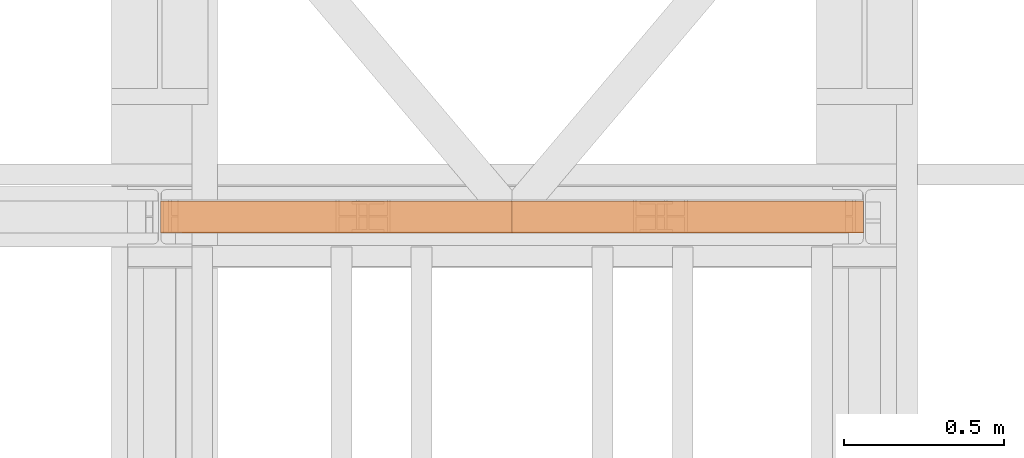
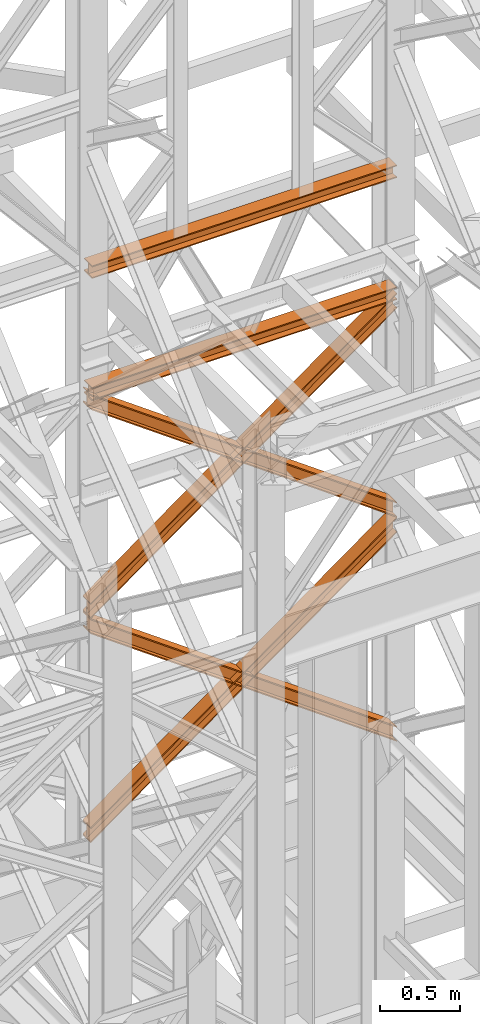
# One storey, part 187 of 208: 6 proxies.
"""IFC2X3 building model written with IfcOpenShell, lengths in millimetres."""

import ifcopenshell
import ifcopenshell.guid

model = None  # the IFC model being written
_history = None  # IfcOwnerHistory: only IFC2X3 demands one
_inside = {}  # id of a spatial element -> (the spatial element, [elements in it])
_under = {}  # id of a project, library or spatial element -> (it, [spatial elements below it])
_declared = {}  # id of a project -> (the project, [libraries it declares])
_typed = {}  # id of a type object -> (the type object, [elements of that type])
_made_of = {}  # id of a material, layer set ... -> (it, [elements and type objects made of it])


def new_model(schema):
    """Start an empty IFC model of exactly this schema.

    Asked for "IFC4X3", IfcOpenShell would pick the latest addendum, in which some entities
    have other attributes; the version numbers below select the first issue.
    IFC2X3 requires an IfcOwnerHistory on every rooted entity: one is made here for all.
    """
    global model, _history
    if schema == "IFC4X3":
        model = ifcopenshell.file(schema_version=(4, 3, 0, 0))
    else:
        model = ifcopenshell.file(schema=schema)
    _inside.clear()
    _under.clear()
    _declared.clear()
    _typed.clear()
    _made_of.clear()
    _history = None
    if model.schema == "IFC2X3":
        org = make("IfcOrganization", Name="unknown")
        user = make(
            "IfcPersonAndOrganization",
            ThePerson=make("IfcPerson", FamilyName="unknown"),
            TheOrganization=org,
        )
        app = make(
            "IfcApplication",
            ApplicationDeveloper=org,
            Version="unknown",
            ApplicationFullName="unknown",
            ApplicationIdentifier="unknown",
        )
        _history = make(
            "IfcOwnerHistory",
            OwningUser=user,
            OwningApplication=app,
            ChangeAction="ADDED",
            CreationDate=0,
        )
    return model


def make(cls, **values):
    """One entity of the class cls with the attributes given. An attribute that is None is left unset."""
    return model.create_entity(
        cls, **{name: value for name, value in values.items() if value is not None}
    )


def entity(cls, *values):
    """Any entity or typed value of the class cls, its attributes in the order of the schema. None: left unset."""
    e = model.create_entity(cls)
    for i, value in enumerate(values):
        if value is not None:
            e[i] = value
    return e


def rooted(cls, **values):
    """An entity with a GlobalId (a new one), such as an element, a storey or a relation."""
    return make(cls, GlobalId=ifcopenshell.guid.new(), OwnerHistory=_history, **values)


def si_unit(unit_type, name, prefix=None):
    """IfcSIUnit, for example si_unit("LENGTHUNIT", "METRE", prefix="MILLI")."""
    return make("IfcSIUnit", UnitType=unit_type, Prefix=prefix, Name=name)


def converted_unit(unit_type, name, factor, base, dimensions=None, offset=None):
    """IfcConversionBasedUnit, such as the inch: factor (a typed value) times the base unit."""
    return make(
        "IfcConversionBasedUnit"
        if offset is None
        else "IfcConversionBasedUnitWithOffset",
        ConversionOffset=offset,
        Dimensions=None
        if dimensions is None
        else entity("IfcDimensionalExponents", *dimensions),
        UnitType=unit_type,
        Name=name,
        ConversionFactor=make(
            "IfcMeasureWithUnit", ValueComponent=factor, UnitComponent=base
        ),
    )


def assignment(units):
    """IfcUnitAssignment: the units of a project."""
    return None if units is None else make("IfcUnitAssignment", Units=units)


def point(xyz):
    """IfcCartesianPoint."""
    return None if xyz is None else make("IfcCartesianPoint", Coordinates=xyz)


def direction(xyz):
    """IfcDirection."""
    return None if xyz is None else make("IfcDirection", DirectionRatios=xyz)


def frame(location, z_axis=None, x_axis=None):
    """IfcAxis2Placement3D, a coordinate frame: its origin and axes. An axis left out is left unset."""
    return make(
        "IfcAxis2Placement3D",
        Location=point(location),
        Axis=direction(z_axis),
        RefDirection=direction(x_axis),
    )


def origin():
    """The frame at (0, 0, 0) with its axes left unset."""
    return frame((0.0, 0.0, 0.0))


def origin_with_axes():
    """The frame at (0, 0, 0) with the z axis (0, 0, 1) and the x axis (1, 0, 0) written out."""
    return frame((0.0, 0.0, 0.0), z_axis=(0.0, 0.0, 1.0), x_axis=(1.0, 0.0, 0.0))


def place(relative_to, where):
    """IfcLocalPlacement: puts the frame where relative to a parent placement (None: the world)."""
    return make(
        "IfcLocalPlacement", PlacementRelTo=relative_to, RelativePlacement=where
    )


def context(
    kind, dimensions, precision=None, world=None, true_north=None, identifier=None
):
    """IfcGeometricRepresentationContext, for example the 3D "Model" context."""
    return make(
        "IfcGeometricRepresentationContext",
        ContextIdentifier=identifier,
        ContextType=kind,
        CoordinateSpaceDimension=dimensions,
        Precision=precision,
        WorldCoordinateSystem=world,
        TrueNorth=true_north,
    )


def subcontext(parent, identifier, kind, view, scale=None):
    """IfcGeometricRepresentationSubContext, for example "Body" below "Model"."""
    return make(
        "IfcGeometricRepresentationSubContext",
        ContextIdentifier=identifier,
        ContextType=kind,
        ParentContext=parent,
        TargetScale=scale,
        TargetView=view,
    )


def project(units=None, contexts=None):
    """IfcProject with its units and contexts."""
    return rooted(
        "IfcProject",
        Name="project",
        RepresentationContexts=contexts,
        UnitsInContext=assignment(units),
    )


def spatial(cls, under=None, at=None, **own):
    """A site, building, storey or space (cls), placed at a placement, below another one or the project."""
    s = rooted(cls, ObjectPlacement=at, **own)
    if under is not None:
        _under.setdefault(under.id(), (under, []))[1].append(s)
    return s


def faces_of(points, faces, orient=None, outer=None):
    """IfcFace entities. A face is a list of loops; a loop is a list of indices into points, from 0.

    orient and outer hold one flag for each loop. By default every Orientation is true, the
    first loop of a face is its IfcFaceOuterBound and the others are IfcFaceBound.
    """
    made = []
    for i, loops in enumerate(faces):
        bounds = []
        for j, loop in enumerate(loops):
            is_outer = j == 0 if outer is None else outer[i][j]
            bounds.append(
                make(
                    "IfcFaceOuterBound" if is_outer else "IfcFaceBound",
                    Bound=make("IfcPolyLoop", Polygon=[points[k] for k in loop]),
                    Orientation=True if orient is None else orient[i][j],
                )
            )
        made.append(make("IfcFace", Bounds=bounds))
    return made


def faceted_brep(points, faces, orient=None, outer=None, voids=None):
    """IfcFacetedBrep: a solid bounded by flat faces; with voids (closed shells), ...WithVoids."""
    shared = [point(p) for p in points]
    hull = make("IfcClosedShell", CfsFaces=faces_of(shared, faces, orient, outer))
    if voids is None:
        return make("IfcFacetedBrep", Outer=hull)
    return make(
        "IfcFacetedBrepWithVoids",
        Outer=hull,
        Voids=[
            make(cls, CfsFaces=faces_of(shared, fs, o, b)) for cls, fs, o, b in voids
        ],
    )


def shape(context_of_items, identifier, shape_type, items):
    """IfcShapeRepresentation: the items that make up one representation, for example the "Body"."""
    return make(
        "IfcShapeRepresentation",
        ContextOfItems=context_of_items,
        RepresentationIdentifier=identifier,
        RepresentationType=shape_type,
        Items=items,
    )


def made_of(thing, what):
    """Note that an element or type object is made of a material, layer set ...; save() writes the relation."""
    if what is not None:
        _made_of.setdefault(what.id(), (what, []))[1].append(thing)
    return thing


def element(
    cls,
    number,
    at=None,
    inside=None,
    cuts=None,
    type_object=None,
    material=None,
    context=None,
    identifier="Body",
    shape_type=None,
    held_by="IfcProductDefinitionShape",
    body=None,
    shapes=None,
    **own,
):
    """One element of the class cls, such as IfcWall. Its Tag is "e" and its number.

    at: its placement. inside: the storey or other place that contains it. cuts: it is an
    opening in that element (IfcRelVoidsElement). A single representation is given by context,
    identifier, shape_type and body (its items); several are given by shapes. held_by: the class
    of the entity that holds the representations. save() writes the other relations.
    """
    e = rooted(cls, Tag="e%d" % number, ObjectPlacement=at, **own)
    if body is not None:
        shapes = [shape(context, identifier, shape_type, body)]
    if shapes is not None:
        e.Representation = make(held_by, Representations=shapes)
    if inside is not None:
        _inside.setdefault(inside.id(), (inside, []))[1].append(e)
    if cuts is not None:
        rooted(
            "IfcRelVoidsElement", RelatingBuildingElement=cuts, RelatedOpeningElement=e
        )
    if type_object is not None:
        _typed.setdefault(type_object.id(), (type_object, []))[1].append(e)
    return made_of(e, material)


def aggregate(whole, parts):
    """IfcRelAggregates: a whole, such as a stair, and the parts it consists of."""
    return rooted("IfcRelAggregates", RelatingObject=whole, RelatedObjects=parts)


def save(model, path):
    """Write the relations noted so far, then the file.

    IfcRelAggregates (storeys below a building ...), IfcRelContainedInSpatialStructure (elements
    in a storey), IfcRelDefinesByType, IfcRelAssociatesMaterial and IfcRelDeclares: one each for
    every whole, place, type object, material and project.
    """
    for whole, parts in _under.values():
        aggregate(whole, parts)
    for where, things in _inside.values():
        rooted(
            "IfcRelContainedInSpatialStructure",
            RelatedElements=things,
            RelatingStructure=where,
        )
    for kind, things in _typed.values():
        rooted("IfcRelDefinesByType", RelatedObjects=things, RelatingType=kind)
    for what, things in _made_of.values():
        rooted("IfcRelAssociatesMaterial", RelatedObjects=things, RelatingMaterial=what)
    for by, libraries in _declared.values():
        rooted("IfcRelDeclares", RelatingContext=by, RelatedDefinitions=libraries)
    model.write(path)


model = new_model("IFC2X3")

# Units and contexts
model_context = context("Model", 3, precision=1e-05, world=origin())
plan_context = context("Plan", 3, precision=1e-05, world=origin())
body_context = subcontext(model_context, "Body", "Model", "MODEL_VIEW")
ifc_project = project(units=[si_unit("LENGTHUNIT", "METRE", prefix="MILLI"), converted_unit("PLANEANGLEUNIT", "DEGREE", entity("IfcPlaneAngleMeasure", 0.0174532925199433), si_unit("PLANEANGLEUNIT", "RADIAN"), dimensions=[0, 0, 0, 0, 0, 0, 0]), si_unit("AREAUNIT", "SQUARE_METRE"), si_unit("VOLUMEUNIT", "CUBIC_METRE")], contexts=[model_context, plan_context])

# Building, storey
building_placement = place(None, origin())
building = spatial("IfcBuilding", under=ifc_project, at=building_placement, CompositionType="COMPLEX")
storey_placement = place(building_placement, origin_with_axes())
storey = spatial("IfcBuildingStorey", under=building, at=storey_placement, Name="Geschoss", CompositionType="ELEMENT")

# Proxies
proxy_1_placement = place(storey_placement, frame((6595.754968528681, -13812.57439031789, 5434.990005364416), z_axis=(0.0, 0.0, 1.0), x_axis=(1.0, 0.0, 0.0)))
element("IfcBuildingElementProxy", 1, at=proxy_1_placement, inside=storey, context=body_context, shape_type="Brep", body=[
    faceted_brep([(2194.25999993293, 0.01000000000021828, 1583.81921929576), (0.01000000000021828, 0.01000000000021828, 0.01000000000112777), (0.01000000000021828, 0.01000000000021828, 9.69256505868816), (2194.25999993293, 0.01000000000021828, 1593.501784354445), (2194.25999993293, 100.0100000000002, 1583.819219295759), (0.01000000000021828, 100.0100000000002, 0.01000000000021828), (0.01000000000021828, 0.01000000000021828, 0.01000000000112777), (2194.25999993293, 0.01000000000021828, 1583.81921929576), (2194.25999993293, 100.0100000000002, 1593.501784354445), (0.01000000000021828, 100.0100000000002, 9.69256505868816), (0.01000000000021828, 100.0100000000002, 0.01000000000021828), (2194.25999993293, 100.0100000000002, 1583.819219295759), (2194.25999993293, 52.51000000000022, 1593.501784354445), (0.01000000000021828, 52.51000000000022, 9.69256505868816), (0.01000000000021828, 100.0100000000002, 9.69256505868816), (2194.25999993293, 100.0100000000002, 1593.501784354445), (2194.259999932929, 52.51000000000022, 1690.327434941312), (0.01000000000021828, 52.51000000000022, 106.5182156455558), (0.01000000000021828, 52.51000000000022, 9.69256505868816), (2194.25999993293, 52.51000000000022, 1593.501784354445), (2194.25999993293, 100.0100000000002, 1690.327434941312), (0.01000000000203727, 100.0100000000002, 106.5182156455558), (0.01000000000021828, 52.51000000000022, 106.5182156455558), (2194.259999932929, 52.51000000000022, 1690.327434941312), (2194.25999993293, 100.0100000000002, 1700.01), (0.01000000000021828, 100.0100000000002, 116.2007807042428), (0.01000000000203727, 100.0100000000002, 106.5182156455558), (2194.25999993293, 100.0100000000002, 1690.327434941312), (2194.259999932929, 0.01000000000021828, 1700.01), (0.01000000000021828, 0.01000000000021828, 116.2007807042428), (0.01000000000021828, 100.0100000000002, 116.2007807042428), (2194.25999993293, 100.0100000000002, 1700.01), (2194.25999993293, 0.01000000000021828, 1690.327434941312), (0.01000000000021828, 0.01000000000021828, 106.5182156455549), (0.01000000000021828, 0.01000000000021828, 116.2007807042428), (2194.259999932929, 0.01000000000021828, 1700.01), (2194.25999993293, 47.51000000000022, 1690.327434941311), (0.01000000000021828, 47.51000000000022, 106.5182156455549), (0.01000000000021828, 0.01000000000021828, 106.5182156455549), (2194.25999993293, 0.01000000000021828, 1690.327434941312), (2194.25999993293, 47.51000000000022, 1593.501784354445), (0.01000000000021828, 47.51000000000022, 9.69256505868816), (0.01000000000021828, 47.51000000000022, 106.5182156455549), (2194.25999993293, 47.51000000000022, 1690.327434941311), (2194.25999993293, 0.01000000000021828, 1593.501784354445), (0.01000000000021828, 0.01000000000021828, 9.69256505868816), (0.01000000000021828, 47.51000000000022, 9.69256505868816), (2194.25999993293, 47.51000000000022, 1593.501784354445), (2194.25999993293, 0.01000000000021828, 1593.501784354445), (2194.25999993293, 47.51000000000022, 1593.501784354445), (2194.25999993293, 47.51000000000022, 1690.327434941311), (2194.25999993293, 0.01000000000021828, 1690.327434941312), (2194.259999932929, 0.01000000000021828, 1700.01), (2194.25999993293, 100.0100000000002, 1700.01), (2194.25999993293, 100.0100000000002, 1690.327434941312), (2194.259999932929, 52.51000000000022, 1690.327434941312), (2194.25999993293, 52.51000000000022, 1593.501784354445), (2194.25999993293, 100.0100000000002, 1593.501784354445), (2194.25999993293, 100.0100000000002, 1583.819219295759), (2194.25999993293, 0.01000000000021828, 1583.81921929576), (0.01000000000021828, 0.01000000000021828, 0.01000000000112777), (0.01000000000021828, 100.0100000000002, 0.01000000000021828), (0.01000000000021828, 100.0100000000002, 9.69256505868816), (0.01000000000021828, 52.51000000000022, 9.69256505868816), (0.01000000000021828, 52.51000000000022, 106.5182156455558), (0.01000000000203727, 100.0100000000002, 106.5182156455558), (0.01000000000021828, 100.0100000000002, 116.2007807042428), (0.01000000000021828, 0.01000000000021828, 116.2007807042428), (0.01000000000021828, 0.01000000000021828, 106.5182156455549), (0.01000000000021828, 47.51000000000022, 106.5182156455549), (0.01000000000021828, 47.51000000000022, 9.69256505868816), (0.01000000000021828, 0.01000000000021828, 9.69256505868816)], [[[0, 1, 2, 3]], [[4, 5, 6, 7]], [[8, 9, 10, 11]], [[12, 13, 14, 15]], [[16, 17, 18, 19]], [[20, 21, 22, 23]], [[24, 25, 26, 27]], [[28, 29, 30, 31]], [[32, 33, 34, 35]], [[36, 37, 38, 39]], [[40, 41, 42, 43]], [[44, 45, 46, 47]], [[48, 49, 50, 51, 52, 53, 54, 55, 56, 57, 58, 59]], [[60, 61, 62, 63, 64, 65, 66, 67, 68, 69, 70, 71]]], orient=[[False], [False], [False], [False], [False], [False], [False], [False], [False], [False], [False], [False], [False], [False]]),
])
proxy_2_placement = place(storey_placement, frame((6595.754968528681, -13812.57439031789, 5434.990005364416), z_axis=(0.0, 0.0, 1.0), x_axis=(1.0, 0.0, 0.0)))
element("IfcBuildingElementProxy", 2, at=proxy_2_placement, inside=storey, context=body_context, shape_type="Brep", body=[
    faceted_brep([(0.01000000000021828, 0.01000000000021828, 1593.501784354445), (2194.25999993293, 0.01000000000021828, 9.692565058686341), (2194.25999993293, 0.01000000000021828, 0.01000000000112777), (0.01000000000021828, 0.01000000000021828, 1583.819219295759), (0.01000000000021828, 0.01000000000021828, 1583.819219295759), (2194.25999993293, 0.01000000000021828, 0.01000000000112777), (2194.25999993293, 100.0100000000002, 0.01000000000021828), (0.01000000000021828, 100.0100000000002, 1583.819219295759), (0.01000000000021828, 100.0100000000002, 1583.819219295759), (2194.25999993293, 100.0100000000002, 0.01000000000021828), (2194.25999993293, 100.0100000000002, 9.692565058686341), (0.01000000000021828, 100.0100000000002, 1593.501784354445), (0.01000000000021828, 100.0100000000002, 1593.501784354445), (2194.25999993293, 100.0100000000002, 9.692565058686341), (2194.25999993293, 52.51000000000022, 9.692565058686341), (0.01000000000021828, 52.51000000000022, 1593.501784354445), (0.01000000000021828, 52.51000000000022, 1593.501784354445), (2194.25999993293, 52.51000000000022, 9.692565058686341), (2194.259999932929, 52.51000000000022, 106.5182156455549), (0.01000000000021828, 52.51000000000022, 1690.327434941313), (0.01000000000021828, 52.51000000000022, 1690.327434941313), (2194.259999932929, 52.51000000000022, 106.5182156455549), (2194.25999993293, 100.0100000000002, 106.5182156455549), (0.01000000000021828, 100.0100000000002, 1690.327434941311), (0.01000000000021828, 100.0100000000002, 1690.327434941311), (2194.25999993293, 100.0100000000002, 106.5182156455549), (2194.259999932929, 100.0100000000002, 116.2007807042419), (0.01000000000021828, 100.0100000000002, 1700.01), (0.01000000000021828, 100.0100000000002, 1700.01), (2194.259999932929, 100.0100000000002, 116.2007807042419), (2194.25999993293, 0.01000000000021828, 116.2007807042419), (0.01000000000021828, 0.01000000000021828, 1700.01), (0.01000000000021828, 0.01000000000021828, 1700.01), (2194.25999993293, 0.01000000000021828, 116.2007807042419), (2194.25999993293, 0.01000000000021828, 106.5182156455549), (0.01000000000021828, 0.01000000000021828, 1690.327434941313), (0.01000000000021828, 0.01000000000021828, 1690.327434941313), (2194.25999993293, 0.01000000000021828, 106.5182156455549), (2194.25999993293, 47.51000000000022, 106.5182156455539), (0.01000000000021828, 47.51000000000022, 1690.327434941311), (0.01000000000021828, 47.51000000000022, 1690.327434941311), (2194.25999993293, 47.51000000000022, 106.5182156455539), (2194.25999993293, 47.51000000000022, 9.692565058686341), (0.01000000000021828, 47.51000000000022, 1593.501784354445), (0.01000000000021828, 47.51000000000022, 1593.501784354445), (2194.25999993293, 47.51000000000022, 9.692565058686341), (2194.25999993293, 0.01000000000021828, 9.692565058686341), (0.01000000000021828, 0.01000000000021828, 1593.501784354445), (2194.25999993293, 0.01000000000021828, 9.692565058686341), (2194.25999993293, 47.51000000000022, 9.692565058686341), (2194.25999993293, 47.51000000000022, 106.5182156455539), (2194.25999993293, 0.01000000000021828, 106.5182156455549), (2194.25999993293, 0.01000000000021828, 116.2007807042419), (2194.259999932929, 100.0100000000002, 116.2007807042419), (2194.25999993293, 100.0100000000002, 106.5182156455549), (2194.259999932929, 52.51000000000022, 106.5182156455549), (2194.25999993293, 52.51000000000022, 9.692565058686341), (2194.25999993293, 100.0100000000002, 9.692565058686341), (2194.25999993293, 100.0100000000002, 0.01000000000021828), (2194.25999993293, 0.01000000000021828, 0.01000000000112777), (0.01000000000021828, 0.01000000000021828, 1583.819219295759), (0.01000000000021828, 100.0100000000002, 1583.819219295759), (0.01000000000021828, 100.0100000000002, 1593.501784354445), (0.01000000000021828, 52.51000000000022, 1593.501784354445), (0.01000000000021828, 52.51000000000022, 1690.327434941313), (0.01000000000021828, 100.0100000000002, 1690.327434941311), (0.01000000000021828, 100.0100000000002, 1700.01), (0.01000000000021828, 0.01000000000021828, 1700.01), (0.01000000000021828, 0.01000000000021828, 1690.327434941313), (0.01000000000021828, 47.51000000000022, 1690.327434941311), (0.01000000000021828, 47.51000000000022, 1593.501784354445), (0.01000000000021828, 0.01000000000021828, 1593.501784354445)], [[[0, 1, 2, 3]], [[4, 5, 6, 7]], [[8, 9, 10, 11]], [[12, 13, 14, 15]], [[16, 17, 18, 19]], [[20, 21, 22, 23]], [[24, 25, 26, 27]], [[28, 29, 30, 31]], [[32, 33, 34, 35]], [[36, 37, 38, 39]], [[40, 41, 42, 43]], [[44, 45, 46, 47]], [[48, 49, 50, 51, 52, 53, 54, 55, 56, 57, 58, 59]], [[60, 61, 62, 63, 64, 65, 66, 67, 68, 69, 70, 71]]], orient=[[False], [False], [False], [False], [False], [False], [False], [False], [False], [False], [False], [False], [False], [False]]),
])
proxy_3_placement = place(storey_placement, frame((6595.754968528681, -13812.57439031789, 7134.990005364416), z_axis=(0.0, 0.0, 1.0), x_axis=(1.0, 0.0, 0.0)))
element("IfcBuildingElementProxy", 3, at=proxy_3_placement, inside=storey, context=body_context, shape_type="Brep", body=[
    faceted_brep([(2194.25999993293, 0.01000000000021828, 1583.81921929576), (0.01000000000021828, 0.01000000000021828, 0.01000000000112777), (0.01000000000021828, 0.01000000000021828, 9.69256505868816), (2194.25999993293, 0.01000000000021828, 1593.501784354445), (2194.25999993293, 100.0100000000002, 1583.819219295758), (0.01000000000021828, 100.0100000000002, 0.01000000000021828), (0.01000000000021828, 0.01000000000021828, 0.01000000000112777), (2194.25999993293, 0.01000000000021828, 1583.81921929576), (2194.25999993293, 100.0100000000002, 1593.501784354445), (0.01000000000021828, 100.0100000000002, 9.69256505868816), (0.01000000000021828, 100.0100000000002, 0.01000000000021828), (2194.25999993293, 100.0100000000002, 1583.819219295758), (2194.25999993293, 52.51000000000022, 1593.501784354445), (0.01000000000021828, 52.51000000000022, 9.69256505868816), (0.01000000000021828, 100.0100000000002, 9.69256505868816), (2194.25999993293, 100.0100000000002, 1593.501784354445), (2194.259999932929, 52.51000000000022, 1690.327434941311), (0.01000000000021828, 52.51000000000022, 106.5182156455558), (0.01000000000021828, 52.51000000000022, 9.69256505868816), (2194.25999993293, 52.51000000000022, 1593.501784354445), (2194.25999993293, 100.0100000000002, 1690.327434941311), (0.01000000000203727, 100.0100000000002, 106.5182156455558), (0.01000000000021828, 52.51000000000022, 106.5182156455558), (2194.259999932929, 52.51000000000022, 1690.327434941311), (2194.25999993293, 100.0100000000002, 1700.01), (0.01000000000021828, 100.0100000000002, 116.2007807042428), (0.01000000000203727, 100.0100000000002, 106.5182156455558), (2194.25999993293, 100.0100000000002, 1690.327434941311), (2194.259999932929, 0.01000000000021828, 1700.01), (0.01000000000021828, 0.01000000000021828, 116.2007807042428), (0.01000000000021828, 100.0100000000002, 116.2007807042428), (2194.25999993293, 100.0100000000002, 1700.01), (2194.25999993293, 0.01000000000021828, 1690.327434941311), (0.01000000000021828, 0.01000000000021828, 106.5182156455549), (0.01000000000021828, 0.01000000000021828, 116.2007807042428), (2194.259999932929, 0.01000000000021828, 1700.01), (2194.25999993293, 47.51000000000022, 1690.327434941311), (0.01000000000021828, 47.51000000000022, 106.5182156455549), (0.01000000000021828, 0.01000000000021828, 106.5182156455549), (2194.25999993293, 0.01000000000021828, 1690.327434941311), (2194.25999993293, 47.51000000000022, 1593.501784354445), (0.01000000000021828, 47.51000000000022, 9.69256505868816), (0.01000000000021828, 47.51000000000022, 106.5182156455549), (2194.25999993293, 47.51000000000022, 1690.327434941311), (2194.25999993293, 0.01000000000021828, 1593.501784354445), (0.01000000000021828, 0.01000000000021828, 9.69256505868816), (0.01000000000021828, 47.51000000000022, 9.69256505868816), (2194.25999993293, 47.51000000000022, 1593.501784354445), (2194.25999993293, 0.01000000000021828, 1593.501784354445), (2194.25999993293, 47.51000000000022, 1593.501784354445), (2194.25999993293, 47.51000000000022, 1690.327434941311), (2194.25999993293, 0.01000000000021828, 1690.327434941311), (2194.259999932929, 0.01000000000021828, 1700.01), (2194.25999993293, 100.0100000000002, 1700.01), (2194.25999993293, 100.0100000000002, 1690.327434941311), (2194.259999932929, 52.51000000000022, 1690.327434941311), (2194.25999993293, 52.51000000000022, 1593.501784354445), (2194.25999993293, 100.0100000000002, 1593.501784354445), (2194.25999993293, 100.0100000000002, 1583.819219295758), (2194.25999993293, 0.01000000000021828, 1583.81921929576), (0.01000000000021828, 0.01000000000021828, 0.01000000000112777), (0.01000000000021828, 100.0100000000002, 0.01000000000021828), (0.01000000000021828, 100.0100000000002, 9.69256505868816), (0.01000000000021828, 52.51000000000022, 9.69256505868816), (0.01000000000021828, 52.51000000000022, 106.5182156455558), (0.01000000000203727, 100.0100000000002, 106.5182156455558), (0.01000000000021828, 100.0100000000002, 116.2007807042428), (0.01000000000021828, 0.01000000000021828, 116.2007807042428), (0.01000000000021828, 0.01000000000021828, 106.5182156455549), (0.01000000000021828, 47.51000000000022, 106.5182156455549), (0.01000000000021828, 47.51000000000022, 9.69256505868816), (0.01000000000021828, 0.01000000000021828, 9.69256505868816)], [[[0, 1, 2, 3]], [[4, 5, 6, 7]], [[8, 9, 10, 11]], [[12, 13, 14, 15]], [[16, 17, 18, 19]], [[20, 21, 22, 23]], [[24, 25, 26, 27]], [[28, 29, 30, 31]], [[32, 33, 34, 35]], [[36, 37, 38, 39]], [[40, 41, 42, 43]], [[44, 45, 46, 47]], [[48, 49, 50, 51, 52, 53, 54, 55, 56, 57, 58, 59]], [[60, 61, 62, 63, 64, 65, 66, 67, 68, 69, 70, 71]]], orient=[[False], [False], [False], [False], [False], [False], [False], [False], [False], [False], [False], [False], [False], [False]]),
])
proxy_4_placement = place(storey_placement, frame((6595.754968528681, -13812.57439031789, 7134.990005364416), z_axis=(0.0, 0.0, 1.0), x_axis=(1.0, 0.0, 0.0)))
element("IfcBuildingElementProxy", 4, at=proxy_4_placement, inside=storey, context=body_context, shape_type="Brep", body=[
    faceted_brep([(0.01000000000021828, 0.01000000000021828, 1593.501784354445), (2194.25999993293, 0.01000000000021828, 9.692565058686341), (2194.25999993293, 0.01000000000021828, 0.01000000000112777), (0.01000000000021828, 0.01000000000021828, 1583.819219295758), (0.01000000000021828, 0.01000000000021828, 1583.819219295758), (2194.25999993293, 0.01000000000021828, 0.01000000000112777), (2194.25999993293, 100.0100000000002, 0.01000000000021828), (0.01000000000021828, 100.0100000000002, 1583.819219295758), (0.01000000000021828, 100.0100000000002, 1583.819219295758), (2194.25999993293, 100.0100000000002, 0.01000000000021828), (2194.25999993293, 100.0100000000002, 9.692565058686341), (0.01000000000021828, 100.0100000000002, 1593.501784354445), (0.01000000000021828, 100.0100000000002, 1593.501784354445), (2194.25999993293, 100.0100000000002, 9.692565058686341), (2194.25999993293, 52.51000000000022, 9.692565058686341), (0.01000000000021828, 52.51000000000022, 1593.501784354445), (0.01000000000021828, 52.51000000000022, 1593.501784354445), (2194.25999993293, 52.51000000000022, 9.692565058686341), (2194.259999932929, 52.51000000000022, 106.5182156455549), (0.01000000000021828, 52.51000000000022, 1690.327434941313), (0.01000000000021828, 52.51000000000022, 1690.327434941313), (2194.259999932929, 52.51000000000022, 106.5182156455549), (2194.25999993293, 100.0100000000002, 106.5182156455549), (0.01000000000021828, 100.0100000000002, 1690.327434941311), (0.01000000000021828, 100.0100000000002, 1690.327434941311), (2194.25999993293, 100.0100000000002, 106.5182156455549), (2194.259999932929, 100.0100000000002, 116.2007807042419), (0.01000000000021828, 100.0100000000002, 1700.01), (0.01000000000021828, 100.0100000000002, 1700.01), (2194.259999932929, 100.0100000000002, 116.2007807042419), (2194.25999993293, 0.01000000000021828, 116.2007807042419), (0.01000000000021828, 0.01000000000021828, 1700.01), (0.01000000000021828, 0.01000000000021828, 1700.01), (2194.25999993293, 0.01000000000021828, 116.2007807042419), (2194.25999993293, 0.01000000000021828, 106.5182156455549), (0.01000000000021828, 0.01000000000021828, 1690.327434941313), (0.01000000000021828, 0.01000000000021828, 1690.327434941313), (2194.25999993293, 0.01000000000021828, 106.5182156455549), (2194.25999993293, 47.51000000000022, 106.5182156455539), (0.01000000000021828, 47.51000000000022, 1690.327434941311), (0.01000000000021828, 47.51000000000022, 1690.327434941311), (2194.25999993293, 47.51000000000022, 106.5182156455539), (2194.25999993293, 47.51000000000022, 9.692565058686341), (0.01000000000021828, 47.51000000000022, 1593.501784354445), (0.01000000000021828, 47.51000000000022, 1593.501784354445), (2194.25999993293, 47.51000000000022, 9.692565058686341), (2194.25999993293, 0.01000000000021828, 9.692565058686341), (0.01000000000021828, 0.01000000000021828, 1593.501784354445), (2194.25999993293, 0.01000000000021828, 9.692565058686341), (2194.25999993293, 47.51000000000022, 9.692565058686341), (2194.25999993293, 47.51000000000022, 106.5182156455539), (2194.25999993293, 0.01000000000021828, 106.5182156455549), (2194.25999993293, 0.01000000000021828, 116.2007807042419), (2194.259999932929, 100.0100000000002, 116.2007807042419), (2194.25999993293, 100.0100000000002, 106.5182156455549), (2194.259999932929, 52.51000000000022, 106.5182156455549), (2194.25999993293, 52.51000000000022, 9.692565058686341), (2194.25999993293, 100.0100000000002, 9.692565058686341), (2194.25999993293, 100.0100000000002, 0.01000000000021828), (2194.25999993293, 0.01000000000021828, 0.01000000000112777), (0.01000000000021828, 0.01000000000021828, 1583.819219295758), (0.01000000000021828, 100.0100000000002, 1583.819219295758), (0.01000000000021828, 100.0100000000002, 1593.501784354445), (0.01000000000021828, 52.51000000000022, 1593.501784354445), (0.01000000000021828, 52.51000000000022, 1690.327434941313), (0.01000000000021828, 100.0100000000002, 1690.327434941311), (0.01000000000021828, 100.0100000000002, 1700.01), (0.01000000000021828, 0.01000000000021828, 1700.01), (0.01000000000021828, 0.01000000000021828, 1690.327434941313), (0.01000000000021828, 47.51000000000022, 1690.327434941311), (0.01000000000021828, 47.51000000000022, 1593.501784354445), (0.01000000000021828, 0.01000000000021828, 1593.501784354445)], [[[0, 1, 2, 3]], [[4, 5, 6, 7]], [[8, 9, 10, 11]], [[12, 13, 14, 15]], [[16, 17, 18, 19]], [[20, 21, 22, 23]], [[24, 25, 26, 27]], [[28, 29, 30, 31]], [[32, 33, 34, 35]], [[36, 37, 38, 39]], [[40, 41, 42, 43]], [[44, 45, 46, 47]], [[48, 49, 50, 51, 52, 53, 54, 55, 56, 57, 58, 59]], [[60, 61, 62, 63, 64, 65, 66, 67, 68, 69, 70, 71]]], orient=[[False], [False], [False], [False], [False], [False], [False], [False], [False], [False], [False], [False], [False], [False]]),
])
proxy_5_placement = place(storey_placement, frame((6605.189158585883, -13812.57439031789, 9710.105713222343), z_axis=(0.0, 0.0, 1.0), x_axis=(1.0, 0.0, 0.0)))
element("IfcBuildingElementProxy", 5, at=proxy_5_placement, inside=storey, context=body_context, shape_type="Brep", body=[
    faceted_brep([(2184.825809875727, 0.01000000000021828, 8.010000000000218), (2184.825809875727, 47.51000000000022, 8.010000000000218), (2184.825809875727, 47.51000000000022, 88.01000000000204), (2184.825809875727, 0.01000000000021828, 88.01000000000204), (2184.825809875727, 0.01000000000021828, 96.01000000000022), (2184.825809875727, 100.0100000000002, 96.01000000000022), (2184.825809875727, 100.0100000000002, 88.01000000000204), (2184.825809875727, 52.51000000000022, 88.01000000000204), (2184.825809875727, 52.51000000000022, 8.010000000000218), (2184.825809875727, 100.0100000000002, 8.010000000000218), (2184.825809875727, 100.0100000000002, 0.01000000000021828), (2184.825809875727, 0.01000000000021828, 0.01000000000021828), (2184.825809875727, 0.01000000000021828, 0.01000000000021828), (0.01000000000021828, 0.01000000000385626, 0.01000000000203727), (0.01000000000021828, 0.01000000000385626, 8.010000000000218), (2184.825809875727, 0.01000000000021828, 8.010000000000218), (2184.825809875727, 100.0100000000002, 0.01000000000021828), (0.01000000000021828, 100.0100000000039, 0.01000000000021828), (0.01000000000021828, 0.01000000000385626, 0.01000000000203727), (2184.825809875727, 0.01000000000021828, 0.01000000000021828), (2184.825809875727, 100.0100000000002, 8.010000000000218), (0.01000000000021828, 100.0100000000039, 8.010000000000218), (0.01000000000021828, 100.0100000000039, 0.01000000000021828), (2184.825809875727, 100.0100000000002, 0.01000000000021828), (2184.825809875727, 52.51000000000022, 8.010000000000218), (0.01000000000021828, 52.51000000000386, 8.010000000000218), (0.01000000000021828, 100.0100000000039, 8.010000000000218), (2184.825809875727, 100.0100000000002, 8.010000000000218), (2184.825809875727, 52.51000000000022, 88.01000000000204), (0.01000000000021828, 52.51000000000386, 88.01000000000204), (0.01000000000021828, 52.51000000000386, 8.010000000000218), (2184.825809875727, 52.51000000000022, 8.010000000000218), (2184.825809875727, 100.0100000000002, 88.01000000000204), (0.01000000000021828, 100.0100000000039, 88.01000000000204), (0.01000000000021828, 52.51000000000386, 88.01000000000204), (2184.825809875727, 52.51000000000022, 88.01000000000204), (2184.825809875727, 100.0100000000002, 96.01000000000022), (0.01000000000021828, 100.0100000000039, 96.01000000000022), (0.01000000000021828, 100.0100000000039, 88.01000000000204), (2184.825809875727, 100.0100000000002, 88.01000000000204), (2184.825809875727, 0.01000000000021828, 96.01000000000022), (0.01000000000021828, 0.01000000000385626, 96.01000000000022), (0.01000000000021828, 100.0100000000039, 96.01000000000022), (2184.825809875727, 100.0100000000002, 96.01000000000022), (2184.825809875727, 0.01000000000021828, 88.01000000000204), (0.01000000000021828, 0.01000000000385626, 88.01000000000022), (0.01000000000021828, 0.01000000000385626, 96.01000000000022), (2184.825809875727, 0.01000000000021828, 96.01000000000022), (2184.825809875727, 47.51000000000022, 88.01000000000204), (0.01000000000021828, 47.51000000000386, 88.01000000000204), (0.01000000000021828, 0.01000000000385626, 88.01000000000022), (2184.825809875727, 0.01000000000021828, 88.01000000000204), (2184.825809875727, 47.51000000000022, 8.010000000000218), (0.01000000000021828, 47.51000000000386, 8.010000000000218), (0.01000000000021828, 47.51000000000386, 88.01000000000204), (2184.825809875727, 47.51000000000022, 88.01000000000204), (2184.825809875727, 0.01000000000021828, 8.010000000000218), (0.01000000000021828, 0.01000000000385626, 8.010000000000218), (0.01000000000021828, 47.51000000000386, 8.010000000000218), (2184.825809875727, 47.51000000000022, 8.010000000000218), (0.01000000000021828, 0.01000000000385626, 8.010000000000218), (0.01000000000021828, 0.01000000000385626, 0.01000000000203727), (0.01000000000021828, 100.0100000000039, 0.01000000000021828), (0.01000000000021828, 100.0100000000039, 8.010000000000218), (0.01000000000021828, 52.51000000000386, 8.010000000000218), (0.01000000000021828, 52.51000000000386, 88.01000000000204), (0.01000000000021828, 100.0100000000039, 88.01000000000204), (0.01000000000021828, 100.0100000000039, 96.01000000000022), (0.01000000000021828, 0.01000000000385626, 96.01000000000022), (0.01000000000021828, 0.01000000000385626, 88.01000000000022), (0.01000000000021828, 47.51000000000386, 88.01000000000204), (0.01000000000021828, 47.51000000000386, 8.010000000000218)], [[[0, 1, 2, 3, 4, 5, 6, 7, 8, 9, 10, 11]], [[12, 13, 14, 15]], [[16, 17, 18, 19]], [[20, 21, 22, 23]], [[24, 25, 26, 27]], [[28, 29, 30, 31]], [[32, 33, 34, 35]], [[36, 37, 38, 39]], [[40, 41, 42, 43]], [[44, 45, 46, 47]], [[48, 49, 50, 51]], [[52, 53, 54, 55]], [[56, 57, 58, 59]], [[60, 61, 62, 63, 64, 65, 66, 67, 68, 69, 70, 71]]], orient=[[False], [False], [False], [False], [False], [False], [False], [False], [False], [False], [False], [False], [False], [False]]),
])
proxy_6_placement = place(storey_placement, frame((6605.189158585883, -13812.57439031789, 8785.007354628786), z_axis=(0.0, 0.0, 1.0), x_axis=(1.0, 0.0, 0.0)))
element("IfcBuildingElementProxy", 6, at=proxy_6_placement, inside=storey, context=body_context, shape_type="Brep", body=[
    faceted_brep([(2184.825809875727, 0.01000000000021828, 8.010000000000218), (2184.825809875727, 47.51000000000022, 8.010000000000218), (2184.825809875727, 47.51000000000022, 88.01000000000204), (2184.825809875727, 0.01000000000021828, 88.01000000000204), (2184.825809875727, 0.01000000000021828, 96.01000000000022), (2184.825809875727, 100.0100000000002, 96.01000000000022), (2184.825809875727, 100.0100000000002, 88.01000000000204), (2184.825809875727, 52.51000000000022, 88.01000000000204), (2184.825809875727, 52.51000000000022, 8.010000000000218), (2184.825809875727, 100.0100000000002, 8.010000000000218), (2184.825809875727, 100.0100000000002, 0.01000000000021828), (2184.825809875727, 0.01000000000021828, 0.01000000000021828), (2184.825809875727, 0.01000000000021828, 0.01000000000021828), (0.01000000000021828, 0.01000000000385626, 0.01000000000203727), (0.01000000000021828, 0.01000000000385626, 8.010000000000218), (2184.825809875727, 0.01000000000021828, 8.010000000000218), (2184.825809875727, 100.0100000000002, 0.01000000000021828), (0.01000000000021828, 100.0100000000039, 0.01000000000021828), (0.01000000000021828, 0.01000000000385626, 0.01000000000203727), (2184.825809875727, 0.01000000000021828, 0.01000000000021828), (2184.825809875727, 100.0100000000002, 8.010000000000218), (0.01000000000021828, 100.0100000000039, 8.010000000000218), (0.01000000000021828, 100.0100000000039, 0.01000000000021828), (2184.825809875727, 100.0100000000002, 0.01000000000021828), (2184.825809875727, 52.51000000000022, 8.010000000000218), (0.01000000000021828, 52.51000000000386, 8.010000000000218), (0.01000000000021828, 100.0100000000039, 8.010000000000218), (2184.825809875727, 100.0100000000002, 8.010000000000218), (2184.825809875727, 52.51000000000022, 88.01000000000204), (0.01000000000021828, 52.51000000000386, 88.01000000000204), (0.01000000000021828, 52.51000000000386, 8.010000000000218), (2184.825809875727, 52.51000000000022, 8.010000000000218), (2184.825809875727, 100.0100000000002, 88.01000000000204), (0.01000000000021828, 100.0100000000039, 88.01000000000204), (0.01000000000021828, 52.51000000000386, 88.01000000000204), (2184.825809875727, 52.51000000000022, 88.01000000000204), (2184.825809875727, 100.0100000000002, 96.01000000000022), (0.01000000000021828, 100.0100000000039, 96.01000000000022), (0.01000000000021828, 100.0100000000039, 88.01000000000204), (2184.825809875727, 100.0100000000002, 88.01000000000204), (2184.825809875727, 0.01000000000021828, 96.01000000000022), (0.01000000000021828, 0.01000000000385626, 96.01000000000022), (0.01000000000021828, 100.0100000000039, 96.01000000000022), (2184.825809875727, 100.0100000000002, 96.01000000000022), (2184.825809875727, 0.01000000000021828, 88.01000000000204), (0.01000000000021828, 0.01000000000385626, 88.01000000000022), (0.01000000000021828, 0.01000000000385626, 96.01000000000022), (2184.825809875727, 0.01000000000021828, 96.01000000000022), (2184.825809875727, 47.51000000000022, 88.01000000000204), (0.01000000000021828, 47.51000000000386, 88.01000000000204), (0.01000000000021828, 0.01000000000385626, 88.01000000000022), (2184.825809875727, 0.01000000000021828, 88.01000000000204), (2184.825809875727, 47.51000000000022, 8.010000000000218), (0.01000000000021828, 47.51000000000386, 8.010000000000218), (0.01000000000021828, 47.51000000000386, 88.01000000000204), (2184.825809875727, 47.51000000000022, 88.01000000000204), (2184.825809875727, 0.01000000000021828, 8.010000000000218), (0.01000000000021828, 0.01000000000385626, 8.010000000000218), (0.01000000000021828, 47.51000000000386, 8.010000000000218), (2184.825809875727, 47.51000000000022, 8.010000000000218), (0.01000000000021828, 0.01000000000385626, 8.010000000000218), (0.01000000000021828, 0.01000000000385626, 0.01000000000203727), (0.01000000000021828, 100.0100000000039, 0.01000000000021828), (0.01000000000021828, 100.0100000000039, 8.010000000000218), (0.01000000000021828, 52.51000000000386, 8.010000000000218), (0.01000000000021828, 52.51000000000386, 88.01000000000204), (0.01000000000021828, 100.0100000000039, 88.01000000000204), (0.01000000000021828, 100.0100000000039, 96.01000000000022), (0.01000000000021828, 0.01000000000385626, 96.01000000000022), (0.01000000000021828, 0.01000000000385626, 88.01000000000022), (0.01000000000021828, 47.51000000000386, 88.01000000000204), (0.01000000000021828, 47.51000000000386, 8.010000000000218)], [[[0, 1, 2, 3, 4, 5, 6, 7, 8, 9, 10, 11]], [[12, 13, 14, 15]], [[16, 17, 18, 19]], [[20, 21, 22, 23]], [[24, 25, 26, 27]], [[28, 29, 30, 31]], [[32, 33, 34, 35]], [[36, 37, 38, 39]], [[40, 41, 42, 43]], [[44, 45, 46, 47]], [[48, 49, 50, 51]], [[52, 53, 54, 55]], [[56, 57, 58, 59]], [[60, 61, 62, 63, 64, 65, 66, 67, 68, 69, 70, 71]]], orient=[[False], [False], [False], [False], [False], [False], [False], [False], [False], [False], [False], [False], [False], [False]]),
])

save(model, "model.ifc")
